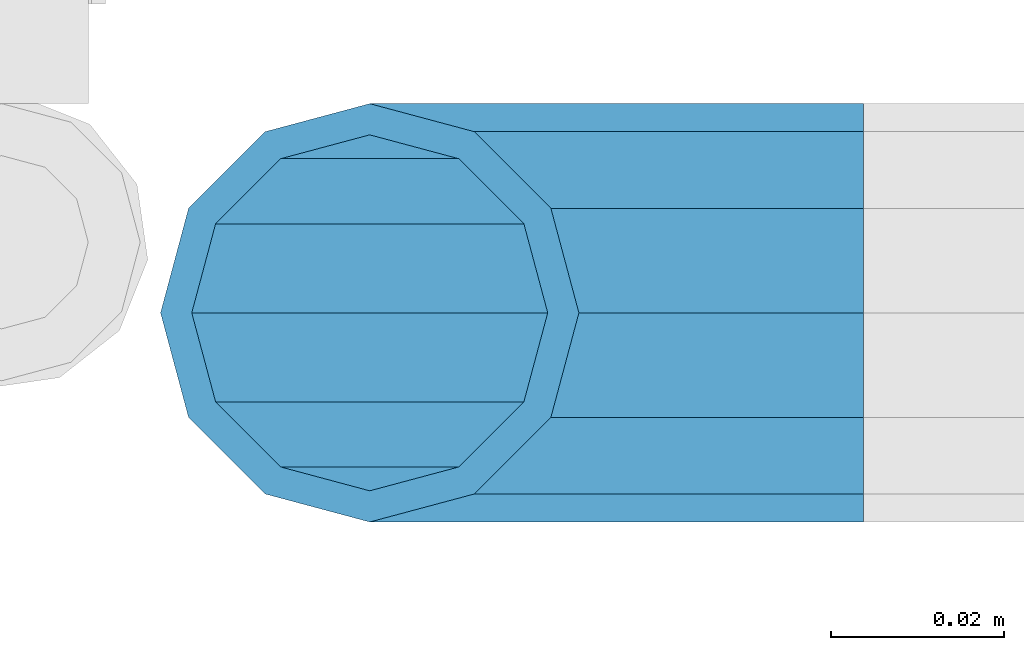
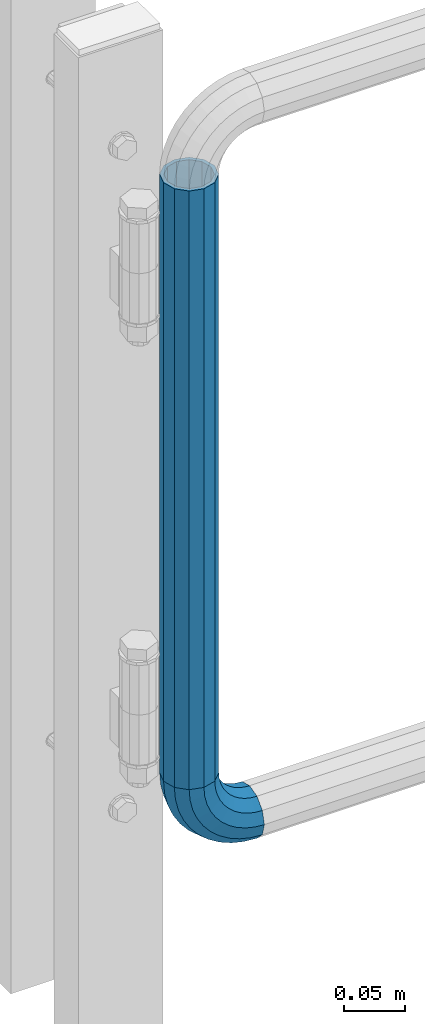
# One storey, part 149 of 208: 1 beam, 1 member.
"""IFC2X3 building model written with IfcOpenShell, lengths in millimetres."""

from ifc_helpers import new_model, si_unit, frame, origin_with_axes, place, context, subcontext, project, spatial, faceted_brep, material, type_object, element, save


model = new_model("IFC2X3")

# Units and contexts
model_context = context("Model", 3, precision=1e-05, world=origin_with_axes())
body_context = subcontext(model_context, "Body", "Model", "MODEL_VIEW")
ifc_project = project(units=[si_unit("LENGTHUNIT", "METRE", prefix="MILLI"), si_unit("AREAUNIT", "SQUARE_METRE"), si_unit("VOLUMEUNIT", "CUBIC_METRE"), si_unit("MASSUNIT", "GRAM", prefix="KILO"), si_unit("TIMEUNIT", "SECOND"), si_unit("PLANEANGLEUNIT", "RADIAN"), si_unit("SOLIDANGLEUNIT", "STERADIAN"), si_unit("THERMODYNAMICTEMPERATUREUNIT", "DEGREE_CELSIUS"), si_unit("LUMINOUSINTENSITYUNIT", "LUMEN")], contexts=[model_context])

# Site, building, storey
site_placement = place(None, origin_with_axes())
site = spatial("IfcSite", under=ifc_project, at=site_placement, CompositionType="ELEMENT")
building_placement = place(site_placement, origin_with_axes())
building = spatial("IfcBuilding", under=site, at=building_placement, Name="Standard", CompositionType="ELEMENT")
storey_placement = place(building_placement, origin_with_axes())
storey = spatial("IfcBuildingStorey", under=building, at=storey_placement, Name="Undefined", CompositionType="ELEMENT", Elevation=0.0)

# Member
ifc_material = material()
member_type = type_object("IfcMemberType", PredefinedType="NOTDEFINED")
member_placement = place(storey_placement, frame((-15494.7539827644, 5941.85399999618, 224.650006544463), z_axis=(0.0, -1.0, 0.0), x_axis=(-0.707106781186548, 0.0, 0.707106781186548)))
element("IfcMember", 1, at=member_placement, inside=storey, type_object=member_type, material=ifc_material, context=body_context, shape_type="Brep", body=[
    faceted_brep([(17.0766287656552, -17.0766287656552, 0.0), (14.7887943220539, -14.7887943220539, -12.0749999999998), (19.0945697419538, -11.1113146999724, -12.0749999999998), (20.9963409898282, -13.7288782624146, 0.0), (8.53831438282759, -8.53831438282759, -20.9145135013941), (13.8988340683954, -3.95999805533756, -20.9145135013941), (0.0, 0.0, -24.1500000000001), (6.80132714696265, 5.80888215173945, -24.1500000000001), (-8.53831438282759, 8.53831438282759, -20.9145135013941), (-0.296179774470147, 15.5777623588165, -20.9145135013941), (-14.7887943220521, 14.7887943220521, -12.0749999999998), (-5.49191544802852, 22.7290790034513, -12.0749999999998), (-17.0766287656552, 17.0766287656552, 0.0), (-7.39368669589931, 25.3466425658935, 0.0), (-14.7887943220521, 14.7887943220521, 12.0749999999998), (-5.49191544802852, 22.7290790034513, 12.0749999999998), (-8.53831438282759, 8.53831438282759, 20.9145135013941), (-0.296179774470147, 15.5777623588165, 20.9145135013941), (0.0, 0.0, 24.1500000000001), (6.80132714696265, 5.80888215173945, 24.1500000000001), (8.53831438282759, -8.53831438282759, 20.9145135013941), (13.8988340683954, -3.95999805533756, 20.9145135013941), (14.7887943220539, -14.7887943220539, 12.0749999999998), (19.0945697419538, -11.1113146999724, 12.0749999999998), (14.5310443533836, -14.5310443533836, 0.0), (12.5842535535485, -12.5842535535485, 10.2750000000001), (17.2620366843166, -8.58904933077247, 10.2750000000001), (18.8803140815726, -10.8164170826676, 0.0), (7.26552217669268, -7.26552217669268, 17.7968220477701), (12.8408206142685, -2.50376746546499, 17.7968220477701), (0.0, 0.0, 20.5500000000002), (6.80132714696265, 5.80888215173945, 20.5500000000002), (-7.26552217669087, 7.26552217669087, 17.7968220477701), (0.761833679658594, 14.1215317689421, 17.7968220477701), (-12.5842535535485, 12.5842535535485, 10.2750000000001), (-3.65938239039133, 20.2068136342514, 10.2750000000001), (-14.5310443533836, 14.5310443533836, 0.0), (-5.27765978764546, 22.4341813861447, 0.0), (-12.5842535535485, 12.5842535535485, -10.2750000000001), (-3.65938239039133, 20.2068136342514, -10.2750000000001), (-7.26552217669087, 7.26552217669087, -17.7968220477701), (0.761833679658594, 14.1215317689421, -17.7968220477701), (0.0, 0.0, -20.5500000000002), (6.80132714696265, 5.80888215173945, -20.5500000000002), (7.26552217669268, -7.26552217669268, -17.7968220477701), (12.8408206142685, -2.50376746546499, -17.7968220477701), (12.5842535535485, -12.5842535535485, -10.2750000000001), (17.2620366843166, -8.58904933077247, -10.2750000000001), (23.9226184787876, -8.15268262886457, -12.0749999999998), (25.3914986111904, -11.0355222080452, 0.0), (19.9095633268353, -0.27661842847192, -20.9145135013941), (14.4276280424801, 10.482285351105, -24.1500000000001), (8.94569275812501, 21.2411891306783, -20.9145135013941), (4.93263760617265, 29.117253331071, -12.0749999999998), (3.46375747377169, 32.0000929102534, 0.0), (4.93263760617265, 29.117253331071, 12.0749999999998), (8.94569275812501, 21.2411891306783, 20.9145135013941), (14.4276280424801, 10.482285351105, 24.1500000000001), (19.9095633268353, -0.27661842847192, 20.9145135013941), (23.9226184787876, -8.15268262886457, 12.0749999999998), (22.5072161777225, -5.3747992032786, 10.2750000000001), (23.7571328121267, -7.82789872096691, 0.0), (19.0923804273043, 1.32719331506814, 17.7968220477701), (14.4276280424801, 10.482285351105, 20.5500000000002), (9.76287565765597, 19.6373773871383, 17.7968220477701), (6.34803990723776, 26.3393699054886, 10.2750000000001), (5.0981232728318, 28.7924694231751, 0.0), (6.34803990723776, 26.3393699054886, -10.2750000000001), (9.76287565765597, 19.6373773871383, -17.7968220477701), (14.4276280424801, 10.482285351105, -20.5500000000002), (19.0923804273043, 1.32719331506814, -17.7968220477701), (22.5072161777225, -5.3747992032786, -10.2750000000001), (29.1540579492776, -5.98574944945176, -12.0749999999998), (30.1538782624175, -9.06287996733772, 0.0), (26.422498055339, 2.42112746692692, -20.9145135013941), (22.6911178482624, 13.9051349011897, -24.1500000000001), (18.9597376411857, 25.3891423354562, -20.9145135013941), (16.2281777472472, 33.7960192518349, -12.0749999999998), (15.2283574341091, 36.873149769719, 0.0), (16.2281777472472, 33.7960192518349, 12.0749999999998), (18.9597376411857, 25.3891423354562, 20.9145135013941), (22.6911178482624, 13.9051349011897, 24.1500000000001), (26.422498055339, 2.42112746692692, 20.9145135013941), (29.1540579492776, -5.98574944945176, 12.0749999999998), (28.1906383068908, -3.0206486766856, 10.2750000000001), (29.041417082668, -5.63907650867441, 0.0), (25.8662674654661, 4.13302919625858, 17.7968220477701), (22.6911178482624, 13.9051349011897, 20.5500000000002), (19.5159682310605, 23.6772406061227, 17.7968220477701), (17.1915973896339, 30.8309184790687, 10.2750000000001), (16.3408186138568, 33.4493463110575, 0.0), (17.1915973896339, 30.8309184790687, -10.2750000000001), (19.5159682310605, 23.6772406061227, -17.7968220477701), (22.6911178482624, 13.9051349011897, -20.5500000000002), (25.8662674654661, 4.13302919625858, -17.7968220477701), (28.1906383068908, -3.0206486766856, -10.2750000000001), (34.660072751507, -4.66387224825667, -12.0749999999998), (35.1662143510621, -7.85952453908249, 0.0), (33.2772681857005, 4.06681217360347, -20.9145135013941), (31.3883220203406, 15.9931488862876, -24.1500000000001), (29.4993758549808, 27.9194855989754, -20.9145135013941), (28.1165712891743, 36.6501700208355, -12.0749999999998), (27.6104296896192, 39.8458223116613, 0.0), (28.1165712891743, 36.6501700208355, 12.0749999999998), (29.4993758549808, 27.9194855989754, 20.9145135013941), (31.3883220203406, 15.9931488862876, 24.1500000000001), (33.2772681857005, 4.06681217360347, 20.9145135013941), (34.660072751507, -4.66387224825667, 12.0749999999998), (34.1723583568, -1.58456474993909, 10.2750000000001), (34.6030502769172, -4.30384651293934, 0.0), (32.995686148628, 5.84465118667504, 17.7968220477701), (31.3883220203406, 15.9931488862876, 20.5500000000002), (29.7809578920533, 26.1416465859038, 17.7968220477701), (28.6042856838831, 33.5708625225197, 10.2750000000001), (28.1735937637659, 36.29014428552, 0.0), (28.6042856838831, 33.5708625225197, -10.2750000000001), (29.7809578920533, 26.1416465859038, -17.7968220477701), (31.3883220203406, 15.9931488862876, -20.5500000000002), (32.995686148628, 5.84465118667504, -17.7968220477701), (34.1723583568, -1.58456474993909, -10.2750000000001), (40.3050865276346, -4.21960002902779, -12.0749999999998), (40.3050865276346, -7.45508652763237, 0.0), (40.3050865276327, 4.61991347236653, -20.9145135013941), (40.3050865276327, 16.6949134723673, -24.1500000000001), (40.3050865276346, 28.7699134723662, -20.9145135013941), (40.3050865276346, 37.6094269737623, -12.0749999999998), (40.3050865276346, 40.8449134723669, 0.0), (40.3050865276346, 37.6094269737623, 12.0749999999998), (40.3050865276346, 28.7699134723662, 20.9145135013941), (40.3050865276327, 16.6949134723673, 24.1500000000001), (40.3050865276327, 4.61991347236653, 20.9145135013941), (40.3050865276346, -4.21960002902779, 12.0749999999998), (40.3050865276327, -1.10190857540329, 10.2750000000001), (40.3050865276346, -3.85508652763383, 0.0), (40.3050865276346, 6.41991347236763, 17.7968220477701), (40.3050865276327, 16.6949134723673, 20.5500000000002), (40.3050865276346, 26.9699134723669, 17.7968220477701), (40.3050865276346, 34.491735520136, 10.2750000000001), (40.3050865276327, 37.2449134723665, 0.0), (40.3050865276346, 34.491735520136, -10.2750000000001), (40.3050865276346, 26.9699134723669, -17.7968220477701), (40.3050865276327, 16.6949134723673, -20.5500000000002), (40.3050865276346, 6.41991347236763, -17.7968220477701), (40.3050865276327, -1.10190857540329, -10.2750000000001), (45.9501003037603, -4.66387224825485, -12.0749999999998), (45.4439587042052, -7.8595245390843, 0.0), (47.3329048695668, 4.06681217360529, -20.9145135013941), (49.2218510349267, 15.9931488862894, -24.1500000000001), (51.1107972002883, 27.9194855989754, -20.9145135013941), (52.4936017660948, 36.6501700208355, -12.0749999999998), (52.9997433656481, 39.8458223116631, 0.0), (52.4936017660948, 36.6501700208355, 12.0749999999998), (51.1107972002883, 27.9194855989754, 20.9145135013941), (49.2218510349267, 15.9931488862894, 24.1500000000001), (47.3329048695668, 4.06681217360529, 20.9145135013941), (45.9501003037603, -4.66387224825485, 12.0749999999998), (46.4378146984691, -1.58456474993909, 10.2750000000001), (46.0071227783501, -4.30384651294116, 0.0), (47.6144869066393, 5.84465118667322, 17.7968220477701), (49.2218510349267, 15.9931488862894, 20.5500000000002), (50.8292151632158, 26.1416465859038, 17.7968220477701), (52.0058873713861, 33.5708625225197, 10.2750000000001), (52.4365792915032, 36.29014428552, 0.0), (52.0058873713861, 33.5708625225197, -10.2750000000001), (50.8292151632158, 26.1416465859038, -17.7968220477701), (49.2218510349267, 15.9931488862894, -20.5500000000002), (47.6144869066393, 5.84465118667322, -17.7968220477701), (46.4378146984691, -1.58456474993909, -10.2750000000001), (51.4561151059897, -5.98574944945358, -12.0749999999998), (50.4562947928516, -9.06287996733772, 0.0), (54.1876749999301, 2.42112746692692, -20.9145135013941), (57.9190552070068, 13.9051349011897, -24.1500000000001), (61.6504354140834, 25.3891423354562, -20.9145135013941), (64.3819953080219, 33.7960192518349, -12.0749999999998), (65.3818156211601, 36.873149769719, 0.0), (64.3819953080219, 33.7960192518349, 12.0749999999998), (61.6504354140834, 25.3891423354562, 20.9145135013941), (57.9190552070068, 13.9051349011897, 24.1500000000001), (54.1876749999301, 2.42112746692692, 20.9145135013941), (51.4561151059897, -5.98574944945358, 12.0749999999998), (52.4195347483783, -3.0206486766856, 10.2750000000001), (51.5687559726011, -5.63907650867441, 0.0), (54.743905589803, 4.13302919625858, 17.7968220477701), (57.9190552070068, 13.9051349011897, 20.5500000000002), (61.0942048242086, 23.6772406061227, 17.7968220477701), (63.4185756656334, 30.8309184790669, 10.2750000000001), (64.2693544414105, 33.4493463110557, 0.0), (63.4185756656334, 30.8309184790669, -10.2750000000001), (61.0942048242086, 23.6772406061227, -17.7968220477701), (57.9190552070068, 13.9051349011897, -20.5500000000002), (54.743905589803, 4.13302919625858, -17.7968220477701), (52.4195347483783, -3.0206486766856, -10.2750000000001), (56.6875545764815, -8.15268262886457, -12.0749999999998), (55.2186744440787, -11.0355222080452, 0.0), (60.7006097284338, -0.27661842847192, -20.9145135013941), (66.182545012789, 10.482285351105, -24.1500000000001), (71.6644802971441, 21.2411891306783, -20.9145135013941), (75.6775354490965, 29.117253331071, -12.0749999999998), (77.1464155814974, 32.0000929102534, 0.0), (75.6775354490965, 29.117253331071, 12.0749999999998), (71.6644802971441, 21.2411891306783, 20.9145135013941), (66.182545012789, 10.482285351105, 24.1500000000001), (60.7006097284338, -0.27661842847192, 20.9145135013941), (56.6875545764815, -8.15268262886457, 12.0749999999998), (58.1029568775466, -5.3747992032786, 10.2750000000001), (56.8530402431425, -7.82789872096691, 0.0), (61.5177926279648, 1.32719331506814, 17.7968220477701), (66.182545012789, 10.482285351105, 20.5500000000002), (70.8472973976113, 19.6373773871401, 17.7968220477701), (74.2621331480332, 26.3393699054868, 10.2750000000001), (75.5120497824355, 28.7924694231733, 0.0), (74.2621331480332, 26.3393699054868, -10.2750000000001), (70.8472973976113, 19.6373773871401, -17.7968220477701), (66.182545012789, 10.482285351105, -20.5500000000002), (61.5177926279648, 1.32719331506814, -17.7968220477701), (58.1029568775466, -5.3747992032786, -10.2750000000001), (61.5156033133135, -11.1113146999742, -12.0749999999998), (59.6138320654427, -13.7288782624164, 0.0), (66.7113389868737, -3.95999805533756, -20.9145135013941), (73.8088459083046, 5.80888215173763, -24.1500000000001), (80.9063528297374, 15.5777623588183, -20.9145135013941), (86.1020885032976, 22.7290790034513, -12.0749999999998), (88.0038597511684, 25.3466425658935, 0.0), (86.1020885032976, 22.7290790034513, 12.0749999999998), (80.9063528297374, 15.5777623588183, 20.9145135013941), (73.8088459083046, 5.80888215173763, 24.1500000000001), (66.7113389868737, -3.95999805533756, 20.9145135013941), (61.5156033133135, -11.1113146999742, 12.0749999999998), (63.3481363709525, -8.58904933077247, 10.2750000000001), (61.7298589736947, -10.8164170826658, 0.0), (67.7693524409988, -2.50376746546317, 17.7968220477701), (73.8088459083046, 5.80888215173763, 20.5500000000002), (79.8483393756105, 14.1215317689421, 17.7968220477701), (84.2695554456586, 20.2068136342532, 10.2750000000001), (85.8878328429146, 22.4341813861447, 0.0), (84.2695554456586, 20.2068136342532, -10.2750000000001), (79.8483393756105, 14.1215317689421, -17.7968220477701), (73.8088459083046, 5.80888215173763, -20.5500000000002), (67.7693524409988, -2.50376746546317, -17.7968220477701), (63.3481363709525, -8.58904933077247, -10.2750000000001), (65.8213787332152, -14.7887943220539, -12.0749999999998), (63.5335442896121, -17.0766287656534, 0.0), (72.0718586724379, -8.53831438282759, -20.9145135013941), (80.6101730552673, 1.81898940354586e-12, -24.1500000000001), (89.1484874380967, 8.53831438282759, -20.9145135013941), (95.3989673773231, 14.7887943220539, -12.0749999999998), (97.6868018209225, 17.0766287656534, 0.0), (95.3989673773231, 14.7887943220539, 12.0749999999998), (89.1484874380967, 8.53831438282759, 20.9145135013941), (80.6101730552673, 1.81898940354586e-12, 24.1500000000001), (72.0718586724379, -8.53831438282759, 20.9145135013941), (65.8213787332152, -14.7887943220539, 12.0749999999998), (68.0259195017188, -12.5842535535503, 10.2750000000001), (66.0791287018856, -14.5310443533836, 0.0), (73.3446508785764, -7.26552217669268, 17.7968220477701), (80.6101730552673, 1.81898940354586e-12, 20.5500000000002), (87.8756952319582, 7.26552217669268, 17.7968220477701), (93.1944266088158, 12.5842535535503, 10.2750000000001), (95.141217408649, 14.5310443533836, 0.0), (93.1944266088158, 12.5842535535503, -10.2750000000001), (87.8756952319582, 7.26552217669268, -17.7968220477701), (80.6101730552673, 1.81898940354586e-12, -20.5500000000002), (73.3446508785764, -7.26552217669268, -17.7968220477701), (68.0259195017188, -12.5842535535503, -10.2750000000001)], [[[0, 1, 2, 3]], [[1, 4, 5, 2]], [[4, 6, 7, 5]], [[6, 8, 9, 7]], [[8, 10, 11, 9]], [[10, 12, 13, 11]], [[12, 14, 15, 13]], [[14, 16, 17, 15]], [[16, 18, 19, 17]], [[18, 20, 21, 19]], [[20, 22, 23, 21]], [[22, 0, 3, 23]], [[24, 25, 26, 27]], [[25, 28, 29, 26]], [[28, 30, 31, 29]], [[30, 32, 33, 31]], [[32, 34, 35, 33]], [[34, 36, 37, 35]], [[36, 38, 39, 37]], [[38, 40, 41, 39]], [[40, 42, 43, 41]], [[42, 44, 45, 43]], [[44, 46, 47, 45]], [[46, 24, 27, 47]], [[22, 20, 18, 16, 14, 12, 10, 8, 6, 4, 1, 0], [46, 44, 42, 40, 38, 36, 34, 32, 30, 28, 25, 24]], [[3, 2, 48, 49]], [[2, 5, 50, 48]], [[5, 7, 51, 50]], [[7, 9, 52, 51]], [[9, 11, 53, 52]], [[11, 13, 54, 53]], [[13, 15, 55, 54]], [[15, 17, 56, 55]], [[17, 19, 57, 56]], [[19, 21, 58, 57]], [[21, 23, 59, 58]], [[23, 3, 49, 59]], [[27, 26, 60, 61]], [[26, 29, 62, 60]], [[29, 31, 63, 62]], [[31, 33, 64, 63]], [[33, 35, 65, 64]], [[35, 37, 66, 65]], [[37, 39, 67, 66]], [[39, 41, 68, 67]], [[41, 43, 69, 68]], [[43, 45, 70, 69]], [[45, 47, 71, 70]], [[47, 27, 61, 71]], [[49, 48, 72, 73]], [[48, 50, 74, 72]], [[50, 51, 75, 74]], [[51, 52, 76, 75]], [[52, 53, 77, 76]], [[53, 54, 78, 77]], [[54, 55, 79, 78]], [[55, 56, 80, 79]], [[56, 57, 81, 80]], [[57, 58, 82, 81]], [[58, 59, 83, 82]], [[59, 49, 73, 83]], [[61, 60, 84, 85]], [[60, 62, 86, 84]], [[62, 63, 87, 86]], [[63, 64, 88, 87]], [[64, 65, 89, 88]], [[65, 66, 90, 89]], [[66, 67, 91, 90]], [[67, 68, 92, 91]], [[68, 69, 93, 92]], [[69, 70, 94, 93]], [[70, 71, 95, 94]], [[71, 61, 85, 95]], [[73, 72, 96, 97]], [[72, 74, 98, 96]], [[74, 75, 99, 98]], [[75, 76, 100, 99]], [[76, 77, 101, 100]], [[77, 78, 102, 101]], [[78, 79, 103, 102]], [[79, 80, 104, 103]], [[80, 81, 105, 104]], [[81, 82, 106, 105]], [[82, 83, 107, 106]], [[83, 73, 97, 107]], [[85, 84, 108, 109]], [[84, 86, 110, 108]], [[86, 87, 111, 110]], [[87, 88, 112, 111]], [[88, 89, 113, 112]], [[89, 90, 114, 113]], [[90, 91, 115, 114]], [[91, 92, 116, 115]], [[92, 93, 117, 116]], [[93, 94, 118, 117]], [[94, 95, 119, 118]], [[95, 85, 109, 119]], [[97, 96, 120, 121]], [[96, 98, 122, 120]], [[98, 99, 123, 122]], [[99, 100, 124, 123]], [[100, 101, 125, 124]], [[101, 102, 126, 125]], [[102, 103, 127, 126]], [[103, 104, 128, 127]], [[104, 105, 129, 128]], [[105, 106, 130, 129]], [[106, 107, 131, 130]], [[107, 97, 121, 131]], [[109, 108, 132, 133]], [[108, 110, 134, 132]], [[110, 111, 135, 134]], [[111, 112, 136, 135]], [[112, 113, 137, 136]], [[113, 114, 138, 137]], [[114, 115, 139, 138]], [[115, 116, 140, 139]], [[116, 117, 141, 140]], [[117, 118, 142, 141]], [[118, 119, 143, 142]], [[119, 109, 133, 143]], [[121, 120, 144, 145]], [[120, 122, 146, 144]], [[122, 123, 147, 146]], [[123, 124, 148, 147]], [[124, 125, 149, 148]], [[125, 126, 150, 149]], [[126, 127, 151, 150]], [[127, 128, 152, 151]], [[128, 129, 153, 152]], [[129, 130, 154, 153]], [[130, 131, 155, 154]], [[131, 121, 145, 155]], [[133, 132, 156, 157]], [[132, 134, 158, 156]], [[134, 135, 159, 158]], [[135, 136, 160, 159]], [[136, 137, 161, 160]], [[137, 138, 162, 161]], [[138, 139, 163, 162]], [[139, 140, 164, 163]], [[140, 141, 165, 164]], [[141, 142, 166, 165]], [[142, 143, 167, 166]], [[143, 133, 157, 167]], [[145, 144, 168, 169]], [[144, 146, 170, 168]], [[146, 147, 171, 170]], [[147, 148, 172, 171]], [[148, 149, 173, 172]], [[149, 150, 174, 173]], [[150, 151, 175, 174]], [[151, 152, 176, 175]], [[152, 153, 177, 176]], [[153, 154, 178, 177]], [[154, 155, 179, 178]], [[155, 145, 169, 179]], [[157, 156, 180, 181]], [[156, 158, 182, 180]], [[158, 159, 183, 182]], [[159, 160, 184, 183]], [[160, 161, 185, 184]], [[161, 162, 186, 185]], [[162, 163, 187, 186]], [[163, 164, 188, 187]], [[164, 165, 189, 188]], [[165, 166, 190, 189]], [[166, 167, 191, 190]], [[167, 157, 181, 191]], [[169, 168, 192, 193]], [[168, 170, 194, 192]], [[170, 171, 195, 194]], [[171, 172, 196, 195]], [[172, 173, 197, 196]], [[173, 174, 198, 197]], [[174, 175, 199, 198]], [[175, 176, 200, 199]], [[176, 177, 201, 200]], [[177, 178, 202, 201]], [[178, 179, 203, 202]], [[179, 169, 193, 203]], [[181, 180, 204, 205]], [[180, 182, 206, 204]], [[182, 183, 207, 206]], [[183, 184, 208, 207]], [[184, 185, 209, 208]], [[185, 186, 210, 209]], [[186, 187, 211, 210]], [[187, 188, 212, 211]], [[188, 189, 213, 212]], [[189, 190, 214, 213]], [[190, 191, 215, 214]], [[191, 181, 205, 215]], [[193, 192, 216, 217]], [[192, 194, 218, 216]], [[194, 195, 219, 218]], [[195, 196, 220, 219]], [[196, 197, 221, 220]], [[197, 198, 222, 221]], [[198, 199, 223, 222]], [[199, 200, 224, 223]], [[200, 201, 225, 224]], [[201, 202, 226, 225]], [[202, 203, 227, 226]], [[203, 193, 217, 227]], [[205, 204, 228, 229]], [[204, 206, 230, 228]], [[206, 207, 231, 230]], [[207, 208, 232, 231]], [[208, 209, 233, 232]], [[209, 210, 234, 233]], [[210, 211, 235, 234]], [[211, 212, 236, 235]], [[212, 213, 237, 236]], [[213, 214, 238, 237]], [[214, 215, 239, 238]], [[215, 205, 229, 239]], [[217, 216, 240, 241]], [[216, 218, 242, 240]], [[218, 219, 243, 242]], [[219, 220, 244, 243]], [[220, 221, 245, 244]], [[221, 222, 246, 245]], [[222, 223, 247, 246]], [[223, 224, 248, 247]], [[224, 225, 249, 248]], [[225, 226, 250, 249]], [[226, 227, 251, 250]], [[227, 217, 241, 251]], [[229, 228, 252, 253]], [[228, 230, 254, 252]], [[230, 231, 255, 254]], [[231, 232, 256, 255]], [[232, 233, 257, 256]], [[233, 234, 258, 257]], [[234, 235, 259, 258]], [[235, 236, 260, 259]], [[236, 237, 261, 260]], [[237, 238, 262, 261]], [[238, 239, 263, 262]], [[239, 229, 253, 263]], [[242, 243, 244, 245, 246, 247, 248, 249, 250, 251, 241, 240], [254, 255, 256, 257, 258, 259, 260, 261, 262, 263, 253, 252]]]),
])

# Beam
beam_type = type_object("IfcBeamType", PredefinedType="NOTDEFINED")
beam_placement = place(storey_placement, frame((-15551.7539827644, 5941.85399999618, 878.350006544462), z_axis=(1.0, 0.0, 0.0), x_axis=(0.0, 0.0, -1.0)))
element("IfcBeam", 2, at=beam_placement, inside=storey, type_object=beam_type, material=ifc_material, context=body_context, shape_type="Brep", body=[
    faceted_brep([(0.0, -20.5500000000002, 0.0), (0.0, -17.7968220477701, 10.2749999999996), (596.700000000001, -17.7968220477701, 10.2749999999996), (596.700000000001, -20.5500000000002, 0.0), (0.0, -10.2750000000001, 17.7968220477705), (596.700000000001, -10.2750000000001, 17.7968220477705), (0.0, 0.0, 20.5500000000002), (596.700000000001, 0.0, 20.5499999999993), (0.0, 10.2750000000001, 17.7968220477705), (596.700000000001, 10.2750000000001, 17.7968220477705), (0.0, 17.7968220477701, 10.2749999999996), (596.700000000001, 17.7968220477701, 10.2749999999996), (0.0, 20.5500000000002, 0.0), (596.700000000001, 20.5500000000002, 0.0), (0.0, 17.7968220477701, -10.2749999999996), (596.700000000001, 17.7968220477701, -10.2749999999996), (0.0, 10.2750000000001, -17.7968220477705), (596.700000000001, 10.2750000000001, -17.7968220477705), (0.0, 0.0, -20.5500000000002), (596.700000000001, 0.0, -20.5499999999993), (0.0, -10.2750000000001, -17.7968220477705), (596.700000000001, -10.2750000000001, -17.7968220477705), (0.0, -17.7968220477701, -10.2749999999996), (596.700000000001, -17.7968220477701, -10.2749999999996), (0.0, -24.1500000000001, 0.0), (0.0, -20.9145135013941, -12.0750000000007), (596.700000000001, -20.9145135013941, -12.0750000000007), (596.700000000001, -24.1500000000001, 0.0), (0.0, -12.0749999999998, -20.914513501395), (596.700000000001, -12.0749999999998, -20.914513501395), (0.0, 0.0, -24.1500000000001), (596.700000000001, 0.0, -24.1499999999996), (0.0, 12.0749999999998, -20.914513501395), (596.700000000001, 12.0749999999998, -20.914513501395), (0.0, 20.9145135013941, -12.0750000000007), (596.700000000001, 20.9145135013941, -12.0750000000007), (0.0, 24.1500000000001, 0.0), (596.700000000001, 24.1500000000001, 0.0), (0.0, 20.9145135013941, 12.0750000000007), (596.700000000001, 20.9145135013941, 12.0750000000007), (0.0, 12.0749999999998, 20.914513501395), (596.700000000001, 12.0749999999998, 20.914513501395), (0.0, 0.0, 24.1500000000001), (596.700000000001, 0.0, 24.1499999999996), (0.0, -12.0749999999998, 20.914513501395), (596.700000000001, -12.0749999999998, 20.914513501395), (0.0, -20.9145135013941, 12.0750000000007), (596.700000000001, -20.9145135013941, 12.0750000000007)], [[[0, 1, 2, 3]], [[1, 4, 5, 2]], [[4, 6, 7, 5]], [[6, 8, 9, 7]], [[8, 10, 11, 9]], [[10, 12, 13, 11]], [[12, 14, 15, 13]], [[14, 16, 17, 15]], [[16, 18, 19, 17]], [[18, 20, 21, 19]], [[20, 22, 23, 21]], [[22, 0, 3, 23]], [[24, 25, 26, 27]], [[25, 28, 29, 26]], [[28, 30, 31, 29]], [[30, 32, 33, 31]], [[32, 34, 35, 33]], [[34, 36, 37, 35]], [[36, 38, 39, 37]], [[38, 40, 41, 39]], [[40, 42, 43, 41]], [[42, 44, 45, 43]], [[44, 46, 47, 45]], [[46, 24, 27, 47]], [[29, 31, 33, 35, 37, 39, 41, 43, 45, 47, 27, 26], [5, 7, 9, 11, 13, 15, 17, 19, 21, 23, 3, 2]], [[46, 44, 42, 40, 38, 36, 34, 32, 30, 28, 25, 24], [22, 20, 18, 16, 14, 12, 10, 8, 6, 4, 1, 0]]]),
])

save(model, "model.ifc")
